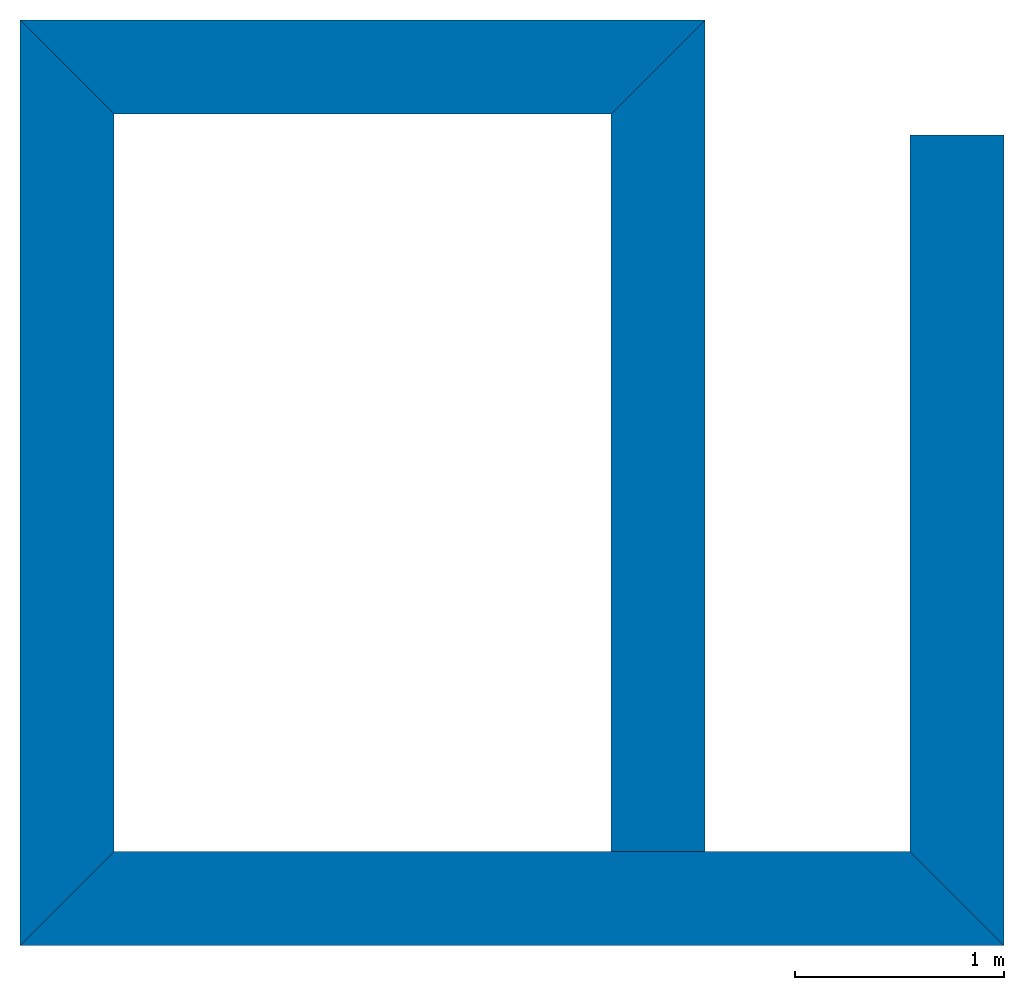
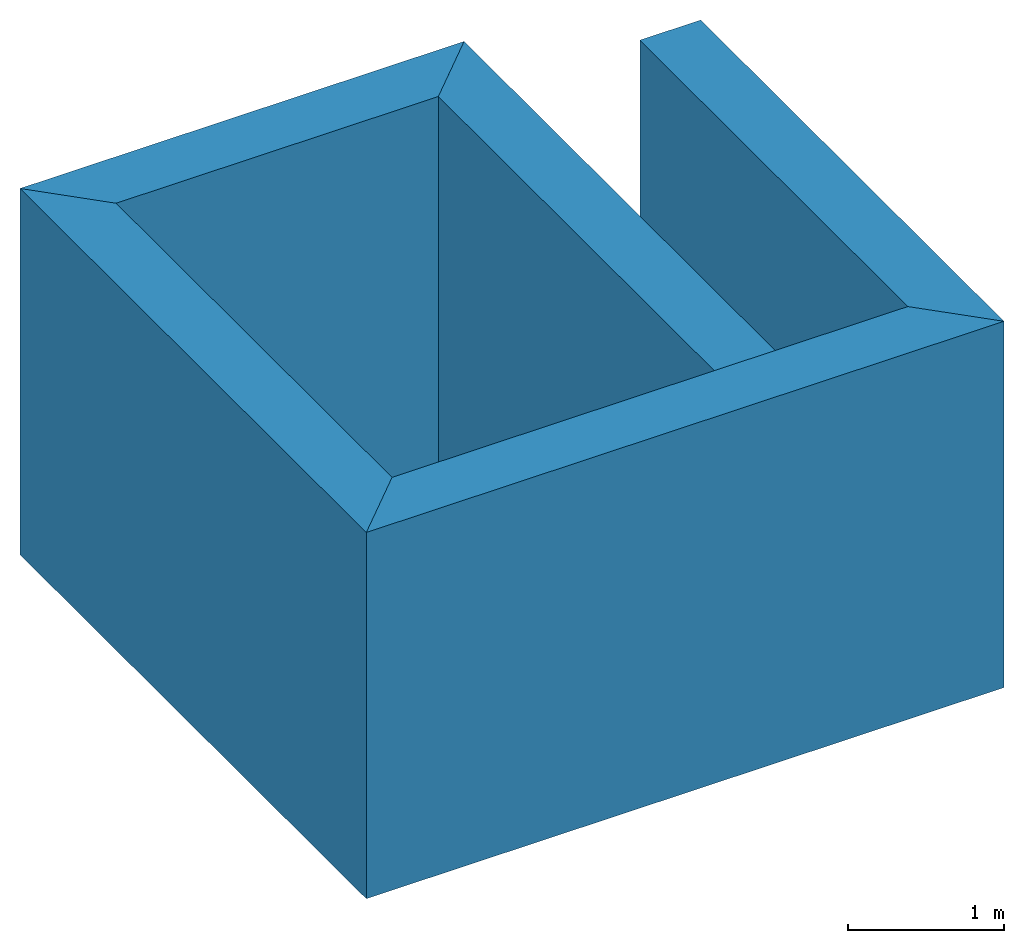
# One storey: 5 walls.
"""IFC4 building model written with IfcOpenShell, lengths in metres."""

import ifcopenshell
import ifcopenshell.guid

model = None  # the IFC model being written
_history = None  # IfcOwnerHistory: only IFC2X3 demands one
_inside = {}  # id of a spatial element -> (the spatial element, [elements in it])
_under = {}  # id of a project, library or spatial element -> (it, [spatial elements below it])
_declared = {}  # id of a project -> (the project, [libraries it declares])
_typed = {}  # id of a type object -> (the type object, [elements of that type])
_made_of = {}  # id of a material, layer set ... -> (it, [elements and type objects made of it])


def new_model(schema):
    """Start an empty IFC model of exactly this schema.

    Asked for "IFC4X3", IfcOpenShell would pick the latest addendum, in which some entities
    have other attributes; the version numbers below select the first issue.
    IFC2X3 requires an IfcOwnerHistory on every rooted entity: one is made here for all.
    """
    global model, _history
    if schema == "IFC4X3":
        model = ifcopenshell.file(schema_version=(4, 3, 0, 0))
    else:
        model = ifcopenshell.file(schema=schema)
    _inside.clear()
    _under.clear()
    _declared.clear()
    _typed.clear()
    _made_of.clear()
    _history = None
    if model.schema == "IFC2X3":
        org = make("IfcOrganization", Name="unknown")
        user = make(
            "IfcPersonAndOrganization",
            ThePerson=make("IfcPerson", FamilyName="unknown"),
            TheOrganization=org,
        )
        app = make(
            "IfcApplication",
            ApplicationDeveloper=org,
            Version="unknown",
            ApplicationFullName="unknown",
            ApplicationIdentifier="unknown",
        )
        _history = make(
            "IfcOwnerHistory",
            OwningUser=user,
            OwningApplication=app,
            ChangeAction="ADDED",
            CreationDate=0,
        )
    return model


def make(cls, **values):
    """One entity of the class cls with the attributes given. An attribute that is None is left unset."""
    return model.create_entity(
        cls, **{name: value for name, value in values.items() if value is not None}
    )


def entity(cls, *values):
    """Any entity or typed value of the class cls, its attributes in the order of the schema. None: left unset."""
    e = model.create_entity(cls)
    for i, value in enumerate(values):
        if value is not None:
            e[i] = value
    return e


def rooted(cls, **values):
    """An entity with a GlobalId (a new one), such as an element, a storey or a relation."""
    return make(cls, GlobalId=ifcopenshell.guid.new(), OwnerHistory=_history, **values)


def si_unit(unit_type, name, prefix=None):
    """IfcSIUnit, for example si_unit("LENGTHUNIT", "METRE", prefix="MILLI")."""
    return make("IfcSIUnit", UnitType=unit_type, Prefix=prefix, Name=name)


def converted_unit(unit_type, name, factor, base, dimensions=None, offset=None):
    """IfcConversionBasedUnit, such as the inch: factor (a typed value) times the base unit."""
    return make(
        "IfcConversionBasedUnit"
        if offset is None
        else "IfcConversionBasedUnitWithOffset",
        ConversionOffset=offset,
        Dimensions=None
        if dimensions is None
        else entity("IfcDimensionalExponents", *dimensions),
        UnitType=unit_type,
        Name=name,
        ConversionFactor=make(
            "IfcMeasureWithUnit", ValueComponent=factor, UnitComponent=base
        ),
    )


def assignment(units):
    """IfcUnitAssignment: the units of a project."""
    return None if units is None else make("IfcUnitAssignment", Units=units)


def point(xyz):
    """IfcCartesianPoint."""
    return None if xyz is None else make("IfcCartesianPoint", Coordinates=xyz)


def direction(xyz):
    """IfcDirection."""
    return None if xyz is None else make("IfcDirection", DirectionRatios=xyz)


def frame(location, z_axis=None, x_axis=None):
    """IfcAxis2Placement3D, a coordinate frame: its origin and axes. An axis left out is left unset."""
    return make(
        "IfcAxis2Placement3D",
        Location=point(location),
        Axis=direction(z_axis),
        RefDirection=direction(x_axis),
    )


def frame_2d(location, x_axis=None):
    """IfcAxis2Placement2D, a coordinate frame in the plane: its origin and x axis."""
    return make(
        "IfcAxis2Placement2D", Location=point(location), RefDirection=direction(x_axis)
    )


def origin_with_axes():
    """The frame at (0, 0, 0) with the z axis (0, 0, 1) and the x axis (1, 0, 0) written out."""
    return frame((0.0, 0.0, 0.0), z_axis=(0.0, 0.0, 1.0), x_axis=(1.0, 0.0, 0.0))


def place(relative_to, where):
    """IfcLocalPlacement: puts the frame where relative to a parent placement (None: the world)."""
    return make(
        "IfcLocalPlacement", PlacementRelTo=relative_to, RelativePlacement=where
    )


def context(
    kind, dimensions, precision=None, world=None, true_north=None, identifier=None
):
    """IfcGeometricRepresentationContext, for example the 3D "Model" context."""
    return make(
        "IfcGeometricRepresentationContext",
        ContextIdentifier=identifier,
        ContextType=kind,
        CoordinateSpaceDimension=dimensions,
        Precision=precision,
        WorldCoordinateSystem=world,
        TrueNorth=true_north,
    )


def subcontext(parent, identifier, kind, view, scale=None):
    """IfcGeometricRepresentationSubContext, for example "Body" below "Model"."""
    return make(
        "IfcGeometricRepresentationSubContext",
        ContextIdentifier=identifier,
        ContextType=kind,
        ParentContext=parent,
        TargetScale=scale,
        TargetView=view,
    )


def project(units=None, contexts=None):
    """IfcProject with its units and contexts."""
    return rooted(
        "IfcProject",
        Name="project",
        RepresentationContexts=contexts,
        UnitsInContext=assignment(units),
    )


def spatial(cls, under=None, at=None, **own):
    """A site, building, storey or space (cls), placed at a placement, below another one or the project."""
    s = rooted(cls, ObjectPlacement=at, **own)
    if under is not None:
        _under.setdefault(under.id(), (under, []))[1].append(s)
    return s


def polyline(points):
    """IfcPolyline through the points."""
    return make("IfcPolyline", Points=[point(p) for p in points])


def outline(outer, holes=None, kind="AREA"):
    """IfcArbitraryClosedProfileDef: a profile drawn as a closed curve; with holes, ...WithVoids."""
    if holes is None:
        return make("IfcArbitraryClosedProfileDef", ProfileType=kind, OuterCurve=outer)
    return make(
        "IfcArbitraryProfileDefWithVoids",
        ProfileType=kind,
        OuterCurve=outer,
        InnerCurves=holes,
    )


def extrude(swept, where, along, depth):
    """IfcExtrudedAreaSolid: the profile swept, set in the frame where, extruded along a direction by depth."""
    return make(
        "IfcExtrudedAreaSolid",
        SweptArea=swept,
        Position=where,
        ExtrudedDirection=direction(along),
        Depth=depth,
    )


def shape(context_of_items, identifier, shape_type, items):
    """IfcShapeRepresentation: the items that make up one representation, for example the "Body"."""
    return make(
        "IfcShapeRepresentation",
        ContextOfItems=context_of_items,
        RepresentationIdentifier=identifier,
        RepresentationType=shape_type,
        Items=items,
    )


def material(Name=None, Category=None):
    """IfcMaterial."""
    return make("IfcMaterial", Name=Name, Category=Category)


def layer(
    of_material, thickness, ventilated=None, Name=None, Category=None, Priority=None
):
    """IfcMaterialLayer: one layer of a wall or slab, of a material (None: an air gap)."""
    return make(
        "IfcMaterialLayer",
        Material=of_material,
        LayerThickness=thickness,
        IsVentilated=ventilated,
        Name=Name,
        Category=Category,
        Priority=Priority,
    )


def layer_set(layers, Name=None):
    """IfcMaterialLayerSet."""
    return make("IfcMaterialLayerSet", MaterialLayers=layers, LayerSetName=Name)


def layer_usage(for_layer_set, set_direction, sense, offset, extent=None):
    """IfcMaterialLayerSetUsage: how a layer set lies in its element."""
    return make(
        "IfcMaterialLayerSetUsage",
        ForLayerSet=for_layer_set,
        LayerSetDirection=set_direction,
        DirectionSense=sense,
        OffsetFromReferenceLine=offset,
        ReferenceExtent=extent,
    )


def made_of(thing, what):
    """Note that an element or type object is made of a material, layer set ...; save() writes the relation."""
    if what is not None:
        _made_of.setdefault(what.id(), (what, []))[1].append(thing)
    return thing


def type_object(cls, material=None, **own):
    """A type object (cls), such as IfcWallType, which elements share."""
    return made_of(rooted(cls, **own), material)


def element(
    cls,
    number,
    at=None,
    inside=None,
    cuts=None,
    type_object=None,
    material=None,
    context=None,
    identifier="Body",
    shape_type=None,
    held_by="IfcProductDefinitionShape",
    body=None,
    shapes=None,
    **own,
):
    """One element of the class cls, such as IfcWall. Its Tag is "e" and its number.

    at: its placement. inside: the storey or other place that contains it. cuts: it is an
    opening in that element (IfcRelVoidsElement). A single representation is given by context,
    identifier, shape_type and body (its items); several are given by shapes. held_by: the class
    of the entity that holds the representations. save() writes the other relations.
    """
    e = rooted(cls, Tag="e%d" % number, ObjectPlacement=at, **own)
    if body is not None:
        shapes = [shape(context, identifier, shape_type, body)]
    if shapes is not None:
        e.Representation = make(held_by, Representations=shapes)
    if inside is not None:
        _inside.setdefault(inside.id(), (inside, []))[1].append(e)
    if cuts is not None:
        rooted(
            "IfcRelVoidsElement", RelatingBuildingElement=cuts, RelatedOpeningElement=e
        )
    if type_object is not None:
        _typed.setdefault(type_object.id(), (type_object, []))[1].append(e)
    return made_of(e, material)


def aggregate(whole, parts):
    """IfcRelAggregates: a whole, such as a stair, and the parts it consists of."""
    return rooted("IfcRelAggregates", RelatingObject=whole, RelatedObjects=parts)


def save(model, path):
    """Write the relations noted so far, then the file.

    IfcRelAggregates (storeys below a building ...), IfcRelContainedInSpatialStructure (elements
    in a storey), IfcRelDefinesByType, IfcRelAssociatesMaterial and IfcRelDeclares: one each for
    every whole, place, type object, material and project.
    """
    for whole, parts in _under.values():
        aggregate(whole, parts)
    for where, things in _inside.values():
        rooted(
            "IfcRelContainedInSpatialStructure",
            RelatedElements=things,
            RelatingStructure=where,
        )
    for kind, things in _typed.values():
        rooted("IfcRelDefinesByType", RelatedObjects=things, RelatingType=kind)
    for what, things in _made_of.values():
        rooted("IfcRelAssociatesMaterial", RelatedObjects=things, RelatingMaterial=what)
    for by, libraries in _declared.values():
        rooted("IfcRelDeclares", RelatingContext=by, RelatedDefinitions=libraries)
    model.write(path)


model = new_model("IFC4")

# Units and contexts
model_context = context("Model", 3, precision=1e-05, world=origin_with_axes())
plan_context = context("Plan", 2, precision=1e-05, world=frame_2d((0.0, 0.0, 0.0), x_axis=(1.0, 0.0, 0.0)))
body_context = subcontext(model_context, "Body", "Model", "MODEL_VIEW")
ifc_project = project(units=[si_unit("VOLUMEUNIT", "CUBIC_METRE"), si_unit("LENGTHUNIT", "METRE"), converted_unit("PLANEANGLEUNIT", "degree", entity("IfcReal", 0.0174532925199433), si_unit("PLANEANGLEUNIT", "RADIAN"), dimensions=[0, 0, 0, 0, 0, 0, 0]), si_unit("AREAUNIT", "SQUARE_METRE")], contexts=[model_context, plan_context])

# Site, building, storey
site_placement = place(None, origin_with_axes())
site = spatial("IfcSite", under=ifc_project, at=site_placement)
building_placement = place(site_placement, origin_with_axes())
building = spatial("IfcBuilding", under=site, at=building_placement, Name="Building")
storey_placement = place(building_placement, frame((0.0, 0.0, -2.20000004768372), z_axis=(0.0, 0.0, 1.0), x_axis=(1.0, 0.0, 0.0)))
storey = spatial("IfcBuildingStorey", under=building, at=storey_placement, Name="SS")

# Walls
ifc_material = material()
ifc_layer = layer(ifc_material, 0.449999988079071)
ifc_layer_set = layer_set([ifc_layer])
ifc_layer_usage_1 = layer_usage(ifc_layer_set, "AXIS2", "POSITIVE", 0.0)
wall_type = type_object("IfcWallType", Name="450mm", PredefinedType="SOLIDWALL", material=ifc_layer_set)
wall_1_placement = place(storey_placement, frame((15.3449993133545, 3.59999990463257, -0.829999923706051), z_axis=(0.0, 0.0, 1.0), x_axis=(1.0, 0.0, 0.0)))
element("IfcWall", 1, at=wall_1_placement, inside=storey, type_object=wall_type, material=ifc_layer_usage_1, Name="Wall", context=body_context, shape_type="SweptSolid", body=[
    extrude(outline(polyline([(-1.82433569431305, -1.50613760948181), (-1.18793988227844, -1.50613760948181), (1.50613749027252, 1.18793940544128), (1.50613820552826, 1.82433605194092), (-1.82433569431305, -1.50613760948181)])), frame((2.35500025749207, 0.224999904632568, 0.0), z_axis=(0.0, 0.0, -1.0), x_axis=(0.707106828689575, 0.707106828689575, 0.0)), (-5.21019627441888e-09, 1.04203925488378e-08, -1.0), 2.85999995838512),
])
ifc_layer_usage_2 = layer_usage(ifc_layer_set, "AXIS2", "POSITIVE", 0.0)
wall_2_placement = place(storey_placement, frame((18.6250019073486, 8.02999973297119, -0.829999923706051), z_axis=(0.0, 0.0, 1.0), x_axis=(-1.0, 3.89414367418794e-07, 0.0)))
element("IfcWall", 2, at=wall_2_placement, inside=storey, type_object=wall_type, material=ifc_layer_usage_2, Name="Wall", context=body_context, shape_type="SweptSolid", body=[
    extrude(outline(polyline([(-1.31875133514404, -1.00055706501007), (-0.68235582113266, -1.00055706501007), (1.00055432319641, 0.682358920574188), (1.00055229663849, 1.31875467300415), (-1.31875133514404, -1.00055706501007)])), frame((1.63999891281128, 0.225000560283661, 0.0), z_axis=(0.0, 0.0, -1.0), x_axis=(0.707105457782745, 0.707108080387115, 0.0)), (5.21019627441888e-09, -5.21019627441888e-09, -1.0), 2.85999995838512),
])
ifc_layer_usage_3 = layer_usage(ifc_layer_set, "AXIS2", "POSITIVE", 0.0)
wall_3_placement = place(storey_placement, frame((18.6250019073486, 4.05000066757202, -0.829999923706051), z_axis=(0.0, 0.0, 1.0), x_axis=(5.52335052361741e-07, 1.0, 0.0)))
element("IfcWall", 3, at=wall_3_placement, inside=storey, type_object=wall_type, material=ifc_layer_usage_3, Name="Wall", context=body_context, shape_type="SweptSolid", body=[
    extrude(outline(polyline([(-0.225002303719521, -1.87749934196472), (0.224998444318771, -1.87749934196472), (0.225001066923141, 1.65249860286713), (-0.224997192621231, 2.10249972343445), (-0.225002303719521, -1.87749934196472)])), frame((1.87749946117401, 0.224999994039536, 0.0), z_axis=(0.0, 0.0, -1.0), x_axis=(7.94727270658768e-07, 1.0, 0.0)), (6.93688495534417e-10, -2.0840680292622e-08, -1.0), 2.85999995838512),
])
ifc_layer_usage_4 = layer_usage(ifc_layer_set, "AXIS2", "POSITIVE", 0.0)
wall_4_placement = place(storey_placement, frame((15.3450031280518, 8.02999973297119, -0.829999923706051), z_axis=(0.0, 0.0, 1.0), x_axis=(-7.58967132696853e-07, -1.0, 0.0)))
element("IfcWall", 4, at=wall_4_placement, inside=storey, type_object=wall_type, material=ifc_layer_usage_4, Name="Wall", context=body_context, shape_type="SweptSolid", body=[
    extrude(outline(polyline([(-1.7253383398056, -1.40714502334595), (-1.08894276618958, -1.40714502334595), (1.40714085102081, 1.08894634246826), (1.40714001655579, 1.7253429889679), (-1.7253383398056, -1.40714502334595)])), frame((2.21499967575073, 0.224999785423279, 0.0), z_axis=(0.0, 0.0, -1.0), x_axis=(0.707105815410614, 0.707107722759247, 0.0)), (0.0, -1.56305883791674e-08, -1.0), 2.85999995838512),
])
ifc_layer_usage_5 = layer_usage(ifc_layer_set, "AXIS2", "POSITIVE", 0.0)
wall_5_placement = place(storey_placement, frame((20.0550003051758, 3.59999990463257, -0.829999923706051), z_axis=(0.0, 0.0, 1.0), x_axis=(5.52335052361741e-07, 1.0, 0.0)))
element("IfcWall", 5, at=wall_5_placement, inside=storey, type_object=wall_type, material=ifc_layer_usage_5, Name="Wall", context=body_context, shape_type="SweptSolid", body=[
    extrude(outline(polyline([(-1.61043620109558, -1.29223954677582), (-0.974039316177368, -1.29223942756653), (1.45133650302887, 1.13314092159271), (1.13313913345337, 1.45133817195892), (-1.61043620109558, -1.29223954677582)])), frame((2.05250144004822, 0.225000992417336, 0.0), z_axis=(0.0, 0.0, -1.0), x_axis=(0.707106113433838, 0.707107543945312, 0.0)), (-1.56305883791674e-08, 5.21019627441888e-09, -1.0), 2.85999995838512),
])

save(model, "model.ifc")
